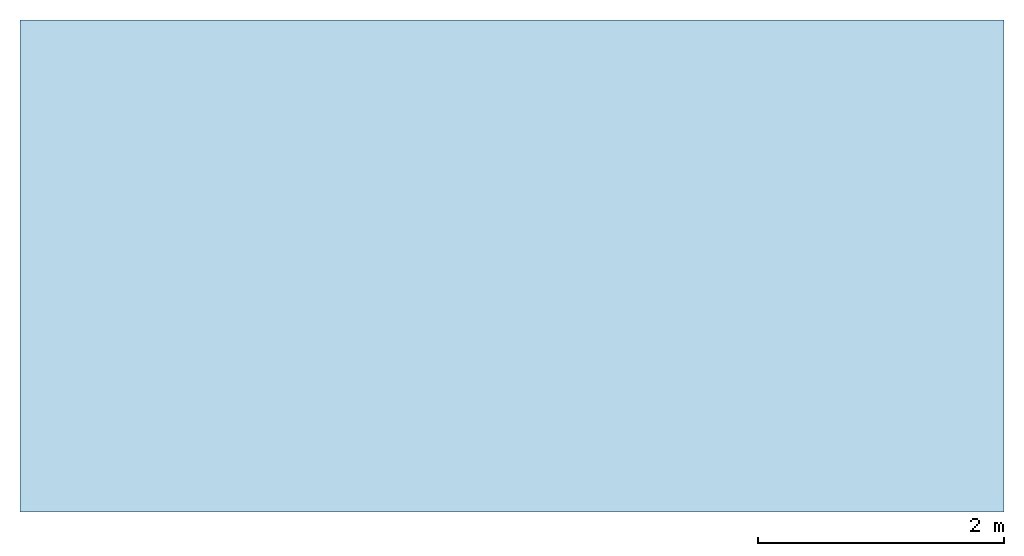
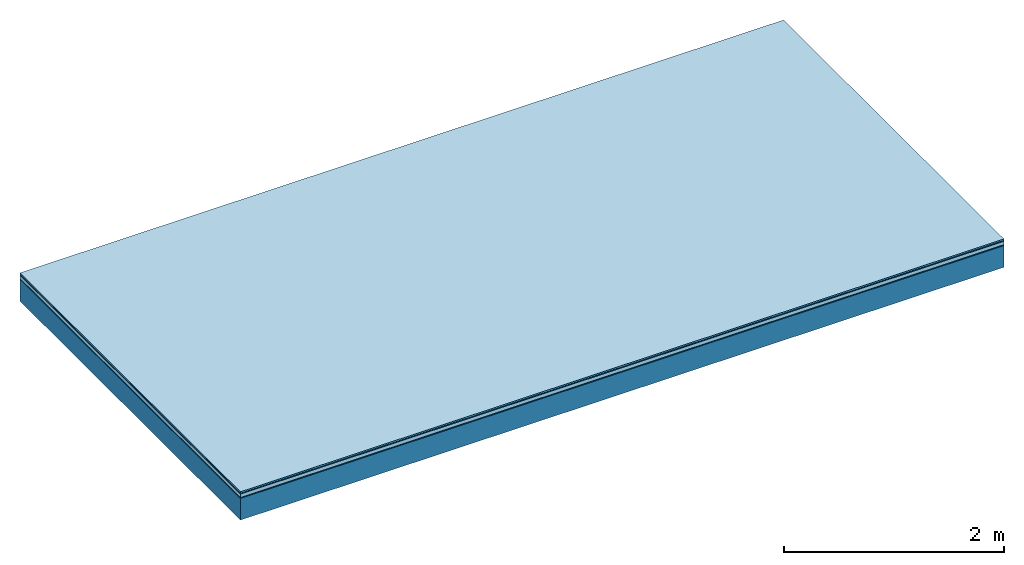
# One storey: 5 plates, 1 member, 1 element without a shape of its own.
"""IFC4 building model written with IfcOpenShell, lengths in metres."""

from ifc_helpers import new_model, si_unit, derived_unit, direction, frame, frame_2d, origin, origin_with_axes, place, context, project, spatial, rectangle, extrude, material, layer, layer_set, type_object, element, aggregate, save


model = new_model("IFC4")

# Units and contexts
plan_context = context("Plan", 3, precision=1e-05, world=origin(), true_north=direction((0.0, 1.0)))
model_context = context("Model", 3, precision=1e-05, world=origin(), true_north=direction((0.0, 1.0)))
ifc_project = project(units=[si_unit("LENGTHUNIT", "METRE"), derived_unit("SOUNDPRESSUREUNIT", [(si_unit("PRESSUREUNIT", "PASCAL", prefix="MICRO"), 0)]), si_unit("ENERGYUNIT", "JOULE", prefix="MEGA"), si_unit("MASSUNIT", "GRAM", prefix="KILO"), derived_unit("THERMALTRANSMITTANCEUNIT", [(si_unit("POWERUNIT", "WATT"), 1), (si_unit("AREAUNIT", "SQUARE_METRE"), -1), (si_unit("THERMODYNAMICTEMPERATUREUNIT", "KELVIN"), -1)]), derived_unit("AREADENSITYUNIT", [(si_unit("MASSUNIT", "GRAM", prefix="KILO"), 1), (si_unit("AREAUNIT", "SQUARE_METRE"), -1)]), derived_unit("USERDEFINED", [(si_unit("ENERGYUNIT", "JOULE", prefix="MEGA"), 1), (si_unit("AREAUNIT", "SQUARE_METRE"), -1)])], contexts=[plan_context, model_context])

# Site, building, storey
site = spatial("IfcSite", under=ifc_project)
building_placement = place(None, origin())
building = spatial("IfcBuilding", under=site, at=building_placement)
storey_placement = place(building_placement, origin())
storey = spatial("IfcBuildingStorey", under=building, at=storey_placement)

# Slab, member, plates
ifc_material_1 = material(Category="11.013")
ifc_layer_1 = layer(ifc_material_1, 0.015, Name="Flooring")
ifc_material_2 = material(Category="03.007")
ifc_layer_2 = layer(ifc_material_2, 0.01, Name="layer")
ifc_material_3 = material(Name="Floor heating system Therm38 standard", Category="03.007")
ifc_layer_3 = layer(ifc_material_3, 0.038, Name="On-material")
ifc_material_4 = material(Name="Wood fiber generic product", Category="10.009")
ifc_layer_4 = layer(ifc_material_4, 0.01, Name="Impact sound insulation")
ifc_material_5 = material(Name="protection", Category="09.007")
ifc_layer_5 = layer(ifc_material_5, 0.0005, Name="Sub-floor")
ifc_material_6 = material(Name="no composite action")
ifc_layer_6 = layer(ifc_material_6, 0.0, Name="Bond")
ifc_layer_7 = layer(None, 0.24, Name="Supporting structure")
ifc_layer_set = layer_set([ifc_layer_1, ifc_layer_2, ifc_layer_3, ifc_layer_4, ifc_layer_5, ifc_layer_6, ifc_layer_7])
slab_type = type_object("IfcSlabType", Name="A2039", PredefinedType="NOTDEFINED", material=ifc_layer_set)
slab_placement = place(None, frame((0.0, 0.0, 0.0), z_axis=(0.0, 0.0, -1.0), x_axis=(1.0, 0.0, 0.0)))
slab = element("IfcSlab", 1, at=slab_placement, inside=storey, type_object=slab_type, material=ifc_layer_set, Name="Slab #1")
ifc_material_7 = material(Name="Solid timber panel")
member_placement = place(slab_placement, origin())
member = element("IfcMember", 2, at=member_placement, material=ifc_material_7, Name="Supporting structure", context=plan_context, shape_type="SweptSolid", body=[
    extrude(rectangle(XDim=1.0, YDim=0.24, at=frame_2d((0.5, 0.12), x_axis=(1.0, 0.0))), frame((0.0, 4.0, 0.0735), z_axis=(0.0, -1.0, 0.0), x_axis=(1.0, 0.0, 0.0)), (0.0, 0.0, 1.0), 4.0),
    extrude(rectangle(XDim=1.0, YDim=0.24, at=frame_2d((0.5, 0.12), x_axis=(1.0, 0.0))), frame((1.0, 4.0, 0.0735), z_axis=(0.0, -1.0, 0.0), x_axis=(1.0, 0.0, 0.0)), (0.0, 0.0, 1.0), 4.0),
    extrude(rectangle(XDim=1.0, YDim=0.24, at=frame_2d((0.5, 0.12), x_axis=(1.0, 0.0))), frame((2.0, 4.0, 0.0735), z_axis=(0.0, -1.0, 0.0), x_axis=(1.0, 0.0, 0.0)), (0.0, 0.0, 1.0), 4.0),
    extrude(rectangle(XDim=1.0, YDim=0.24, at=frame_2d((0.5, 0.12), x_axis=(1.0, 0.0))), frame((3.0, 4.0, 0.0735), z_axis=(0.0, -1.0, 0.0), x_axis=(1.0, 0.0, 0.0)), (0.0, 0.0, 1.0), 4.0),
    extrude(rectangle(XDim=1.0, YDim=0.24, at=frame_2d((0.5, 0.12), x_axis=(1.0, 0.0))), frame((4.0, 4.0, 0.0735), z_axis=(0.0, -1.0, 0.0), x_axis=(1.0, 0.0, 0.0)), (0.0, 0.0, 1.0), 4.0),
    extrude(rectangle(XDim=1.0, YDim=0.24, at=frame_2d((0.5, 0.12), x_axis=(1.0, 0.0))), frame((5.0, 4.0, 0.0735), z_axis=(0.0, -1.0, 0.0), x_axis=(1.0, 0.0, 0.0)), (0.0, 0.0, 1.0), 4.0),
    extrude(rectangle(XDim=1.0, YDim=0.24, at=frame_2d((0.5, 0.12), x_axis=(1.0, 0.0))), frame((6.0, 4.0, 0.0735), z_axis=(0.0, -1.0, 0.0), x_axis=(1.0, 0.0, 0.0)), (0.0, 0.0, 1.0), 4.0),
    extrude(rectangle(XDim=1.0, YDim=0.24, at=frame_2d((0.5, 0.12), x_axis=(1.0, 0.0))), frame((7.0, 4.0, 0.0735), z_axis=(0.0, -1.0, 0.0), x_axis=(1.0, 0.0, 0.0)), (0.0, 0.0, 1.0), 4.0),
])
plate_1_placement = place(slab_placement, origin())
plate_1 = element("IfcPlate", 3, at=plate_1_placement, material=ifc_material_1, Name="Flooring", context=plan_context, shape_type="SweptSolid", body=[
    extrude(rectangle(XDim=8.0, YDim=4.0, at=frame_2d((4.0, 2.0), x_axis=(1.0, 0.0))), origin_with_axes(), (0.0, 0.0, 1.0), 0.015),
])
plate_2_placement = place(slab_placement, origin())
plate_2 = element("IfcPlate", 4, at=plate_2_placement, material=ifc_material_2, Name="layer", context=plan_context, shape_type="SweptSolid", body=[
    extrude(rectangle(XDim=8.0, YDim=4.0, at=frame_2d((4.0, 2.0), x_axis=(1.0, 0.0))), frame((0.0, 0.0, 0.015), z_axis=(0.0, 0.0, 1.0), x_axis=(1.0, 0.0, 0.0)), (0.0, 0.0, 1.0), 0.01),
])
plate_3_placement = place(slab_placement, origin())
plate_3 = element("IfcPlate", 5, at=plate_3_placement, material=ifc_material_3, Name="On-material", context=plan_context, shape_type="SweptSolid", body=[
    extrude(rectangle(XDim=8.0, YDim=4.0, at=frame_2d((4.0, 2.0), x_axis=(1.0, 0.0))), frame((0.0, 0.0, 0.025), z_axis=(0.0, 0.0, 1.0), x_axis=(1.0, 0.0, 0.0)), (0.0, 0.0, 1.0), 0.038),
])
plate_4_placement = place(slab_placement, origin())
plate_4 = element("IfcPlate", 6, at=plate_4_placement, material=ifc_material_4, Name="Impact sound insulation", context=plan_context, shape_type="SweptSolid", body=[
    extrude(rectangle(XDim=8.0, YDim=4.0, at=frame_2d((4.0, 2.0), x_axis=(1.0, 0.0))), frame((0.0, 0.0, 0.063), z_axis=(0.0, 0.0, 1.0), x_axis=(1.0, 0.0, 0.0)), (0.0, 0.0, 1.0), 0.01),
])
plate_5_placement = place(slab_placement, origin())
plate_5 = element("IfcPlate", 7, at=plate_5_placement, material=ifc_material_5, Name="Sub-floor", context=plan_context, shape_type="SweptSolid", body=[
    extrude(rectangle(XDim=8.0, YDim=4.0, at=frame_2d((4.0, 2.0), x_axis=(1.0, 0.0))), frame((0.0, 0.0, 0.073), z_axis=(0.0, 0.0, 1.0), x_axis=(1.0, 0.0, 0.0)), (0.0, 0.0, 1.0), 0.0005),
])
aggregate(slab, [plate_1, plate_2, plate_3, plate_4, plate_5, member])

save(model, "model.ifc")
